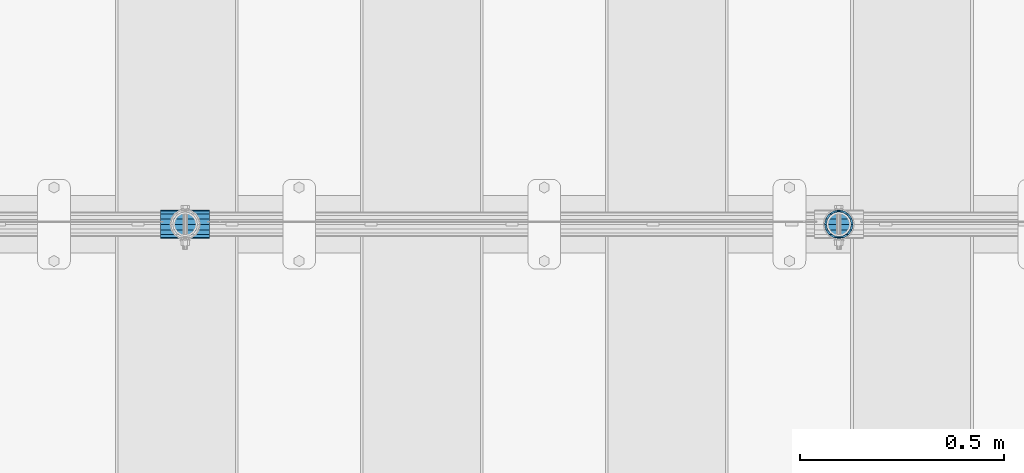
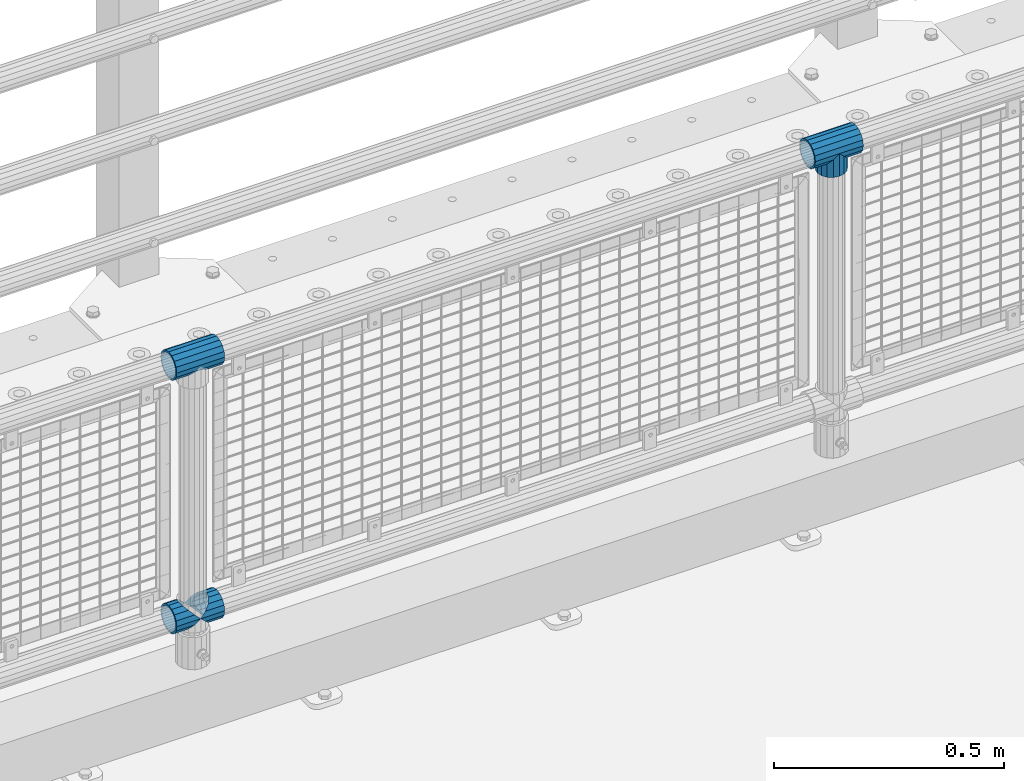
# One storey, part 152 of 247: 5 beams.
"""IFC2X3 building model written with IfcOpenShell, lengths in millimetres."""

from ifc_helpers import new_model, si_unit, frame, origin_with_axes, place, context, subcontext, project, spatial, faceted_brep, material, type_object, element, save


model = new_model("IFC2X3")

# Units and contexts
model_context = context("Model", 3, precision=1e-05, world=origin_with_axes())
body_context = subcontext(model_context, "Body", "Model", "MODEL_VIEW")
ifc_project = project(units=[si_unit("LENGTHUNIT", "METRE", prefix="MILLI"), si_unit("AREAUNIT", "SQUARE_METRE"), si_unit("VOLUMEUNIT", "CUBIC_METRE"), si_unit("MASSUNIT", "GRAM", prefix="KILO"), si_unit("TIMEUNIT", "SECOND"), si_unit("PLANEANGLEUNIT", "RADIAN"), si_unit("SOLIDANGLEUNIT", "STERADIAN"), si_unit("THERMODYNAMICTEMPERATUREUNIT", "DEGREE_CELSIUS"), si_unit("LUMINOUSINTENSITYUNIT", "LUMEN")], contexts=[model_context])

# Site, building, storey
site_placement = place(None, origin_with_axes())
site = spatial("IfcSite", under=ifc_project, at=site_placement, CompositionType="ELEMENT")
building_placement = place(site_placement, origin_with_axes())
building = spatial("IfcBuilding", under=site, at=building_placement, Name="Standard", CompositionType="ELEMENT")
storey_placement = place(building_placement, origin_with_axes())
storey = spatial("IfcBuildingStorey", under=building, at=storey_placement, Name="Undefined", CompositionType="ELEMENT", Elevation=0.0)

# Beams
ifc_material = material(Name="Misc_Undefined")
beam_type = type_object("IfcBeamType", PredefinedType="NOTDEFINED")
beam_1_placement = place(storey_placement, frame((8621.0, 7664.5, 969.849999999999), z_axis=(0.0, 1.0, 0.0), x_axis=(0.0, 0.0, -1.0)))
element("IfcBeam", 1, at=beam_1_placement, inside=storey, type_object=beam_type, material=ifc_material, context=body_context, shape_type="Brep", body=[
    faceted_brep([(0.0, 0.0, 35.1499999999996), (13.4513226476338, 13.4513226476329, 32.4743655677721), (13.4513226476338, -13.4513226476329, 32.4743655677721), (24.8548033587067, -16.3810424080045, -24.8548033587067), (24.8548033587067, -24.8548033587072, -24.8548033587067), (32.4743655677721, -32.4743655677717, -13.4513226476329), (32.4743655677721, -26.8123795176766, -13.4513226476329), (27.1226768591059, -21.4606908090117, -21.4606908090118), (0.0, 0.0, -35.1499999999996), (13.4513226476338, -13.4513226476329, -32.4743655677721), (13.4513226476338, 13.4513226476329, -32.4743655677721), (20.0882031229885, -11.6144421722805, -28.0397438117179), (16.6306603983739, 0.0, -30.3500000000004), (20.0882031229885, 11.6144421722805, -28.0397438117179), (24.8548033587067, 16.3810424080029, -24.8548033587067), (24.8548033587067, 24.8548033587072, -24.8548033587067), (27.1226768591059, 21.4606908090117, -21.4606908090118), (32.4743655677721, 26.8123795176755, -13.4513226476329), (32.4743655677721, 32.4743655677717, -13.4513226476329), (32.8397438117172, 28.0397438117175, -11.6144421722802), (35.1499999999996, 30.35, 0.0), (35.1499999999996, 35.15, 0.0), (32.8397438117172, 28.0397438117175, 11.6144421722802), (32.4743655677721, 26.8123795176755, 13.4513226476329), (32.4743655677721, 32.4743655677717, 13.4513226476329), (27.1226768591096, 21.4606908090117, 21.4606908090118), (24.8548033587067, 16.3810424080046, 24.8548033587067), (24.8548033587067, 24.8548033587072, 24.8548033587067), (20.0882031229812, 11.6144421722805, 28.0397438117179), (16.6306603983649, 0.0, 30.3500000000004), (20.0882031229812, -11.6144421722805, 28.0397438117179), (24.8548033587067, -16.3810424080045, 24.8548033587067), (24.8548033587067, -24.8548033587072, 24.8548033587067), (27.1226768591096, -21.4606908090117, 21.4606908090118), (32.4743655677721, -26.8123795176755, 13.4513226476329), (32.4743655677721, -32.4743655677717, 13.4513226476329), (32.8397438117172, -28.0397438117175, 11.6144421722802), (35.1499999999996, -30.35, 0.0), (35.1499999999996, -35.15, 0.0), (32.8397438117172, -28.0397438117175, -11.6144421722802), (60.1499999999996, -24.8548033587072, -24.8548033587067), (60.1499999999996, -32.4743655677717, -13.4513226476329), (60.1499999999996, -13.4513226476329, -32.4743655677721), (60.1499999999996, 0.0, -35.1499999999996), (60.1499999999996, 13.4513226476329, -32.4743655677721), (60.1499999999996, 24.8548033587072, -24.8548033587067), (60.1499999999996, 32.4743655677717, -13.4513226476329), (60.1499999999996, 35.15, 0.0), (60.1499999999996, 32.4743655677717, 13.4513226476329), (60.1499999999996, 24.8548033587072, 24.8548033587067), (60.1499999999996, 13.4513226476329, 32.4743655677721), (60.1499999999996, 0.0, 35.1499999999996), (60.1499999999996, -13.4513226476329, 32.4743655677721), (60.1499999999996, -24.8548033587072, 24.8548033587067), (60.1499999999996, -32.4743655677717, 13.4513226476329), (60.1499999999996, -35.15, 0.0), (60.1499999999996, -21.4606908090117, 21.4606908090118), (60.1499999999996, -11.6144421722805, 28.0397438117179), (60.1499999999996, 0.0, 30.3500000000004), (60.1499999999996, 11.6144421722805, 28.0397438117179), (60.1499999999996, 21.4606908090117, 21.4606908090118), (60.1499999999996, 28.0397438117175, 11.6144421722802), (60.1499999999996, 30.35, 0.0), (60.1499999999996, 28.0397438117175, -11.6144421722802), (60.1499999999996, 21.4606908090117, -21.4606908090118), (60.1499999999996, 11.6144421722805, -28.0397438117179), (60.1499999999996, 0.0, -30.3500000000004), (60.1499999999996, -11.6144421722805, -28.0397438117179), (60.1499999999996, -21.4606908090117, -21.4606908090118), (60.1499999999996, -28.0397438117175, -11.6144421722802), (60.1499999999996, -30.35, 0.0), (60.1499999999996, -28.0397438117175, 11.6144421722802)], [[[0, 1, 2]], [[3, 4, 5, 6, 7]], [[8, 9, 10]], [[10, 9, 4, 3, 11, 12, 13, 14, 15]], [[15, 14, 16, 17, 18]], [[18, 17, 19, 20, 21]], [[21, 20, 22, 23, 24]], [[24, 23, 25, 26, 27]], [[27, 26, 28, 29, 30, 31, 32, 2, 1]], [[33, 34, 35, 32, 31]], [[36, 37, 38, 35, 34]], [[6, 5, 38, 37, 39]], [[40, 41, 5, 4]], [[42, 40, 4, 9]], [[43, 42, 9, 8]], [[44, 43, 8, 10]], [[45, 44, 10, 15]], [[46, 45, 15, 18]], [[47, 46, 18, 21]], [[48, 47, 21, 24]], [[49, 48, 24, 27]], [[50, 49, 27, 1]], [[51, 50, 1, 0]], [[52, 51, 0, 2]], [[53, 52, 2, 32]], [[54, 53, 32, 35]], [[55, 54, 35, 38]], [[41, 55, 38, 5]], [[40, 42, 43, 44, 45, 46, 47, 48, 49, 50, 51, 52, 53, 54, 55, 41], [56, 57, 58, 59, 60, 61, 62, 63, 64, 65, 66, 67, 68, 69, 70, 71]], [[71, 70, 37, 36]], [[56, 71, 36, 34, 33]], [[57, 56, 33, 31, 30]], [[58, 57, 30, 29]], [[59, 58, 29, 28]], [[25, 60, 59, 28, 26]], [[22, 61, 60, 25, 23]], [[62, 61, 22, 20]], [[63, 62, 20, 19]], [[64, 63, 19, 17, 16]], [[65, 64, 16, 14, 13]], [[66, 65, 13, 12]], [[67, 66, 12, 11]], [[7, 68, 67, 11, 3]], [[39, 69, 68, 7, 6]], [[70, 69, 39, 37]]]),
])
beam_2_placement = place(storey_placement, frame((8560.85, 7664.5, 969.849999999999), z_axis=(0.0, 0.0, 1.0), x_axis=(1.0, 0.0, 0.0)))
element("IfcBeam", 2, at=beam_2_placement, inside=storey, type_object=beam_type, material=ifc_material, context=body_context, shape_type="Brep", body=[
    faceted_brep([(88.1897438117176, -11.6144421722802, -28.0397438117176), (88.1897438117176, -11.6144421722802, -32.8397438117175), (86.9623795176758, -13.4513226476329, -32.4743655677718), (81.6106908090114, -21.4606908090118, -27.1226768591068), (81.6106908090114, -21.4606908090118, -21.4606908090117), (76.5310424080035, -24.8548033587067, -24.8548033587072), (71.7644421722798, -28.0397438117179, -20.0882031229845), (71.7644421722798, -28.0397438117179, -11.6144421722805), (60.1499999999996, -30.3500000000004, -16.6306603983671), (60.1499999999996, -30.35, 0.0), (48.5355578277195, -28.0397438117179, -20.0882031229845), (48.5355578277195, -28.0397438117179, -11.6144421722805), (43.7689575919958, -24.8548033587067, -24.8548033587072), (38.6893091909878, -21.4606908090118, -27.1226768591068), (38.6893091909878, -21.4606908090118, -21.4606908090117), (33.3376204823217, -13.4513226476329, -32.4743655677718), (32.1102561882817, -11.6144421722802, -32.8397438117175), (32.1102561882817, -11.6144421722802, -28.0397438117176), (29.7999999999993, 0.0, -35.15), (29.7999999999993, 0.0, -30.35), (32.1102561882817, 11.6144421722802, -32.8397438117174), (32.1102561882817, 11.6144421722802, -28.0397438117176), (33.3376204823235, 13.4513226476329, -32.4743655677718), (38.6893091909878, 21.4606908090118, -27.122676859108), (38.6893091909878, 21.4606908090118, -21.4606908090117), (43.7689575919976, 24.8548033587067, -24.8548033587072), (48.5355578277195, 28.0397438117179, -20.0882031229829), (48.5355578277195, 28.0397438117179, -11.6144421722805), (60.1499999999996, 30.3500000000004, -16.6306603983655), (60.1499999999996, 30.35, 0.0), (71.7644421722798, 28.0397438117179, -20.0882031229829), (71.7644421722798, 28.0397438117179, -11.6144421722805), (76.5310424080035, 24.8548033587067, -24.8548033587072), (81.6106908090114, 21.4606908090118, -27.122676859108), (81.6106908090114, 21.4606908090118, -21.4606908090117), (86.9623795176758, 13.4513226476329, -32.4743655677718), (88.1897438117176, 11.6144421722802, -32.8397438117174), (88.1897438117176, 11.6144421722802, -28.0397438117176), (90.5, 0.0, -35.15), (90.5, 0.0, -30.35), (0.0, -21.4606908090118, -21.4606908090118), (0.0, -28.0397438117179, -11.6144421722802), (0.0, -11.6144421722802, -28.0397438117179), (0.0, 0.0, -30.3500000000004), (0.0, 11.6144421722802, -28.0397438117179), (0.0, 21.4606908090118, -21.4606908090118), (0.0, 28.0397438117179, -11.6144421722802), (0.0, 30.3500000000004, 0.0), (0.0, 32.4743655677721, -13.4513226476338), (0.0, 35.1499999999996, 0.0), (120.299999999999, 35.1499999999996, 0.0), (120.299999999999, 32.4743655677721, -13.4513226476329), (0.0, 32.4743655677721, 13.4513226476338), (120.299999999999, 32.4743655677721, 13.4513226476329), (0.0, 24.8548033587067, 24.8548033587067), (120.299999999999, 24.8548033587067, 24.8548033587072), (0.0, 13.4513226476329, 32.4743655677721), (120.299999999999, 13.4513226476329, 32.4743655677718), (0.0, 0.0, 35.1499999999996), (120.299999999999, 0.0, 35.15), (0.0, -13.4513226476329, 32.4743655677721), (120.299999999999, -13.4513226476329, 32.4743655677718), (0.0, -24.8548033587067, 24.8548033587067), (120.299999999999, -24.8548033587067, 24.8548033587072), (0.0, -32.4743655677721, 13.4513226476338), (120.299999999999, -32.4743655677721, 13.4513226476329), (0.0, -35.1499999999996, 0.0), (120.299999999999, -35.1499999999996, 0.0), (0.0, -32.4743655677721, -13.4513226476338), (120.299999999999, -32.4743655677721, -13.4513226476329), (0.0, 24.8548033587067, -24.8548033587067), (0.0, 13.4513226476329, -32.4743655677721), (0.0, 0.0, -35.1499999999996), (0.0, -13.4513226476329, -32.4743655677721), (0.0, -24.8548033587067, -24.8548033587067), (0.0, 28.0397438117179, 11.6144421722802), (0.0, 21.4606908090118, 21.4606908090118), (0.0, 11.6144421722802, 28.0397438117179), (0.0, 0.0, 30.3500000000004), (0.0, -11.6144421722802, 28.0397438117179), (0.0, -21.4606908090118, 21.4606908090118), (0.0, -28.0397438117179, 11.6144421722802), (0.0, -30.3500000000004, 0.0), (120.299999999999, -30.3500000000004, 0.0), (120.299999999999, -28.0397438117179, -11.6144421722805), (120.299999999999, -21.4606908090118, -21.4606908090117), (120.299999999999, -11.6144421722802, -28.0397438117176), (120.299999999999, 0.0, -30.35), (120.299999999999, 21.4606908090118, -21.4606908090117), (120.299999999999, 28.0397438117179, -11.6144421722805), (120.299999999999, 11.6144421722802, -28.0397438117176), (120.299999999999, 30.3500000000004, 0.0), (120.299999999999, 28.0397438117179, 11.6144421722805), (120.299999999999, 21.4606908090118, 21.4606908090117), (120.299999999999, 11.6144421722802, 28.0397438117176), (120.299999999999, 0.0, 30.35), (120.299999999999, -11.6144421722802, 28.0397438117176), (120.299999999999, -21.4606908090118, 21.4606908090117), (120.299999999999, -28.0397438117179, 11.6144421722805), (120.299999999999, -24.8548033587067, -24.8548033587072), (120.299999999999, -13.4513226476329, -32.4743655677718), (120.299999999999, 0.0, -35.15), (120.299999999999, 13.4513226476329, -32.4743655677718), (120.299999999999, 24.8548033587067, -24.8548033587072)], [[[0, 1, 2, 3, 4]], [[4, 3, 5, 6, 7]], [[7, 6, 8, 9]], [[9, 8, 10, 11]], [[11, 10, 12, 13, 14]], [[14, 13, 15, 16, 17]], [[17, 16, 18, 19]], [[19, 18, 20, 21]], [[21, 20, 22, 23, 24]], [[24, 23, 25, 26, 27]], [[27, 26, 28, 29]], [[29, 28, 30, 31]], [[31, 30, 32, 33, 34]], [[34, 33, 35, 36, 37]], [[37, 36, 38, 39]], [[39, 38, 1, 0]], [[40, 41, 11, 14]], [[42, 40, 14, 17]], [[43, 42, 17, 19]], [[44, 43, 19, 21]], [[45, 44, 21, 24]], [[46, 45, 24, 27]], [[47, 46, 27, 29]], [[48, 49, 50, 51]], [[49, 52, 53, 50]], [[52, 54, 55, 53]], [[54, 56, 57, 55]], [[56, 58, 59, 57]], [[58, 60, 61, 59]], [[60, 62, 63, 61]], [[62, 64, 65, 63]], [[64, 66, 67, 65]], [[66, 68, 69, 67]], [[64, 62, 60, 58, 56, 54, 52, 49, 48, 70, 71, 72, 73, 74, 68, 66], [41, 40, 42, 43, 44, 45, 46, 47, 75, 76, 77, 78, 79, 80, 81, 82]], [[41, 82, 9, 11]], [[83, 84, 7, 9]], [[84, 85, 4, 7]], [[85, 86, 0, 4]], [[86, 87, 39, 0]], [[88, 89, 31, 34]], [[90, 88, 34, 37]], [[87, 90, 37, 39]], [[89, 91, 29, 31]], [[75, 47, 29, 91, 92]], [[76, 75, 92, 93]], [[77, 76, 93, 94]], [[78, 77, 94, 95]], [[79, 78, 95, 96]], [[80, 79, 96, 97]], [[81, 80, 97, 98]], [[9, 82, 81, 98, 83]], [[99, 100, 101, 102, 103, 51, 50, 53, 55, 57, 59, 61, 63, 65, 67, 69], [97, 96, 95, 94, 93, 92, 91, 89, 88, 90, 87, 86, 85, 84, 83, 98]], [[35, 102, 101, 38, 36]], [[32, 103, 102, 35, 33]], [[28, 26, 25, 70, 48, 51, 103, 32, 30]], [[22, 71, 70, 25, 23]], [[18, 72, 71, 22, 20]], [[73, 72, 18, 16, 15]], [[74, 73, 15, 13, 12]], [[99, 69, 68, 74, 12, 10, 8, 6, 5]], [[100, 99, 5, 3, 2]], [[101, 100, 2, 1, 38]]]),
])
beam_3_placement = place(storey_placement, frame((6960.85, 7664.5, 969.849999999999), z_axis=(0.0, 0.0, 1.0), x_axis=(1.0, 0.0, 0.0)))
element("IfcBeam", 3, at=beam_3_placement, inside=storey, type_object=beam_type, material=ifc_material, context=body_context, shape_type="Brep", body=[
    faceted_brep([(88.1897438117176, -11.6144421722802, -28.0397438117176), (88.1897438117176, -11.6144421722802, -32.8397438117175), (86.9623795176758, -13.4513226476329, -32.4743655677718), (81.6106908090114, -21.4606908090118, -27.1226768591068), (81.6106908090114, -21.4606908090118, -21.4606908090117), (76.5310424080035, -24.8548033587067, -24.8548033587072), (71.7644421722798, -28.0397438117179, -20.0882031229845), (71.7644421722798, -28.0397438117179, -11.6144421722805), (60.1499999999996, -30.3500000000004, -16.6306603983671), (60.1499999999996, -30.35, 0.0), (48.5355578277195, -28.0397438117179, -20.0882031229845), (48.5355578277195, -28.0397438117179, -11.6144421722805), (43.7689575919958, -24.8548033587067, -24.8548033587072), (38.6893091909878, -21.4606908090118, -27.1226768591068), (38.6893091909878, -21.4606908090118, -21.4606908090117), (33.3376204823217, -13.4513226476329, -32.4743655677718), (32.1102561882817, -11.6144421722802, -32.8397438117175), (32.1102561882817, -11.6144421722802, -28.0397438117176), (29.7999999999993, 0.0, -35.15), (29.7999999999993, 0.0, -30.35), (32.1102561882817, 11.6144421722802, -32.8397438117174), (32.1102561882817, 11.6144421722802, -28.0397438117176), (33.3376204823235, 13.4513226476329, -32.4743655677718), (38.6893091909878, 21.4606908090118, -27.122676859108), (38.6893091909878, 21.4606908090118, -21.4606908090117), (43.7689575919976, 24.8548033587067, -24.8548033587072), (48.5355578277195, 28.0397438117179, -20.0882031229829), (48.5355578277195, 28.0397438117179, -11.6144421722805), (60.1499999999996, 30.3500000000004, -16.6306603983655), (60.1499999999996, 30.35, 0.0), (71.7644421722798, 28.0397438117179, -20.0882031229829), (71.7644421722798, 28.0397438117179, -11.6144421722805), (76.5310424080035, 24.8548033587067, -24.8548033587072), (81.6106908090114, 21.4606908090118, -27.122676859108), (81.6106908090114, 21.4606908090118, -21.4606908090117), (86.9623795176758, 13.4513226476329, -32.4743655677718), (88.1897438117176, 11.6144421722802, -32.8397438117174), (88.1897438117176, 11.6144421722802, -28.0397438117176), (90.5, 0.0, -35.15), (90.5, 0.0, -30.35), (0.0, -21.4606908090118, -21.4606908090118), (0.0, -28.0397438117179, -11.6144421722802), (0.0, -11.6144421722802, -28.0397438117179), (0.0, 0.0, -30.3500000000004), (0.0, 11.6144421722802, -28.0397438117179), (0.0, 21.4606908090118, -21.4606908090118), (0.0, 28.0397438117179, -11.6144421722802), (0.0, 30.3500000000004, 0.0), (0.0, 32.4743655677721, -13.4513226476338), (0.0, 35.1499999999996, 0.0), (120.299999999999, 35.1499999999996, 0.0), (120.299999999999, 32.4743655677721, -13.4513226476329), (0.0, 32.4743655677721, 13.4513226476338), (120.299999999999, 32.4743655677721, 13.4513226476329), (0.0, 24.8548033587067, 24.8548033587067), (120.299999999999, 24.8548033587067, 24.8548033587072), (0.0, 13.4513226476329, 32.4743655677721), (120.299999999999, 13.4513226476329, 32.4743655677718), (0.0, 0.0, 35.1499999999996), (120.299999999999, 0.0, 35.15), (0.0, -13.4513226476329, 32.4743655677721), (120.299999999999, -13.4513226476329, 32.4743655677718), (0.0, -24.8548033587067, 24.8548033587067), (120.299999999999, -24.8548033587067, 24.8548033587072), (0.0, -32.4743655677721, 13.4513226476338), (120.299999999999, -32.4743655677721, 13.4513226476329), (0.0, -35.1499999999996, 0.0), (120.299999999999, -35.1499999999996, 0.0), (0.0, -32.4743655677721, -13.4513226476338), (120.299999999999, -32.4743655677721, -13.4513226476329), (0.0, 24.8548033587067, -24.8548033587067), (0.0, 13.4513226476329, -32.4743655677721), (0.0, 0.0, -35.1499999999996), (0.0, -13.4513226476329, -32.4743655677721), (0.0, -24.8548033587067, -24.8548033587067), (0.0, 28.0397438117179, 11.6144421722802), (0.0, 21.4606908090118, 21.4606908090118), (0.0, 11.6144421722802, 28.0397438117179), (0.0, 0.0, 30.3500000000004), (0.0, -11.6144421722802, 28.0397438117179), (0.0, -21.4606908090118, 21.4606908090118), (0.0, -28.0397438117179, 11.6144421722802), (0.0, -30.3500000000004, 0.0), (120.299999999999, -30.3500000000004, 0.0), (120.299999999999, -28.0397438117179, -11.6144421722805), (120.299999999999, -21.4606908090118, -21.4606908090117), (120.299999999999, -11.6144421722802, -28.0397438117176), (120.299999999999, 0.0, -30.35), (120.299999999999, 21.4606908090118, -21.4606908090117), (120.299999999999, 28.0397438117179, -11.6144421722805), (120.299999999999, 11.6144421722802, -28.0397438117176), (120.299999999999, 30.3500000000004, 0.0), (120.299999999999, 28.0397438117179, 11.6144421722805), (120.299999999999, 21.4606908090118, 21.4606908090117), (120.299999999999, 11.6144421722802, 28.0397438117176), (120.299999999999, 0.0, 30.35), (120.299999999999, -11.6144421722802, 28.0397438117176), (120.299999999999, -21.4606908090118, 21.4606908090117), (120.299999999999, -28.0397438117179, 11.6144421722805), (120.299999999999, -24.8548033587067, -24.8548033587072), (120.299999999999, -13.4513226476329, -32.4743655677718), (120.299999999999, 0.0, -35.15), (120.299999999999, 13.4513226476329, -32.4743655677718), (120.299999999999, 24.8548033587067, -24.8548033587072)], [[[0, 1, 2, 3, 4]], [[4, 3, 5, 6, 7]], [[7, 6, 8, 9]], [[9, 8, 10, 11]], [[11, 10, 12, 13, 14]], [[14, 13, 15, 16, 17]], [[17, 16, 18, 19]], [[19, 18, 20, 21]], [[21, 20, 22, 23, 24]], [[24, 23, 25, 26, 27]], [[27, 26, 28, 29]], [[29, 28, 30, 31]], [[31, 30, 32, 33, 34]], [[34, 33, 35, 36, 37]], [[37, 36, 38, 39]], [[39, 38, 1, 0]], [[40, 41, 11, 14]], [[42, 40, 14, 17]], [[43, 42, 17, 19]], [[44, 43, 19, 21]], [[45, 44, 21, 24]], [[46, 45, 24, 27]], [[47, 46, 27, 29]], [[48, 49, 50, 51]], [[49, 52, 53, 50]], [[52, 54, 55, 53]], [[54, 56, 57, 55]], [[56, 58, 59, 57]], [[58, 60, 61, 59]], [[60, 62, 63, 61]], [[62, 64, 65, 63]], [[64, 66, 67, 65]], [[66, 68, 69, 67]], [[64, 62, 60, 58, 56, 54, 52, 49, 48, 70, 71, 72, 73, 74, 68, 66], [41, 40, 42, 43, 44, 45, 46, 47, 75, 76, 77, 78, 79, 80, 81, 82]], [[41, 82, 9, 11]], [[83, 84, 7, 9]], [[84, 85, 4, 7]], [[85, 86, 0, 4]], [[86, 87, 39, 0]], [[88, 89, 31, 34]], [[90, 88, 34, 37]], [[87, 90, 37, 39]], [[89, 91, 29, 31]], [[75, 47, 29, 91, 92]], [[76, 75, 92, 93]], [[77, 76, 93, 94]], [[78, 77, 94, 95]], [[79, 78, 95, 96]], [[80, 79, 96, 97]], [[81, 80, 97, 98]], [[9, 82, 81, 98, 83]], [[99, 100, 101, 102, 103, 51, 50, 53, 55, 57, 59, 61, 63, 65, 67, 69], [97, 96, 95, 94, 93, 92, 91, 89, 88, 90, 87, 86, 85, 84, 83, 98]], [[35, 102, 101, 38, 36]], [[32, 103, 102, 35, 33]], [[28, 26, 25, 70, 48, 51, 103, 32, 30]], [[22, 71, 70, 25, 23]], [[18, 72, 71, 22, 20]], [[73, 72, 18, 16, 15]], [[74, 73, 15, 13, 12]], [[99, 69, 68, 74, 12, 10, 8, 6, 5]], [[100, 99, 5, 3, 2]], [[101, 100, 2, 1, 38]]]),
])
beam_4_placement = place(storey_placement, frame((6960.85, 7664.5, 298.17), z_axis=(0.0, 1.0, 0.0), x_axis=(1.0, 0.0, 0.0)))
element("IfcBeam", 4, at=beam_4_placement, inside=storey, type_object=beam_type, material=ifc_material, context=body_context, shape_type="Brep", body=[
    faceted_brep([(60.1499999999996, 0.0, -35.1499999999996), (46.6986773523668, 13.4513226476329, -32.4743655677721), (46.6986773523668, -13.4513226476329, -32.4743655677721), (33.0273231408919, 21.4606908090117, 21.4606908090118), (27.675634432228, 26.8123795176755, 13.4513226476329), (27.675634432228, 32.4743655677717, 13.4513226476329), (35.2951966412925, 24.8548033587072, 24.8548033587067), (35.2951966412925, 16.3810424080048, 24.8548033587067), (27.3102561882824, 28.0397438117175, 11.6144421722802), (24.9999999999995, 30.35, 0.0), (24.9999999999995, 35.15, 0.0), (27.675634432228, 26.8123795176764, -13.4513226476329), (27.675634432228, 32.4743655677717, -13.4513226476329), (27.310256188282, 28.0397438117175, -11.6144421722802), (35.2951966412925, 16.3810424080032, -24.8548033587067), (35.2951966412925, 24.8548033587072, -24.8548033587067), (33.0273231408928, 21.4606908090117, -21.4606908090118), (40.0617968770157, 11.6144421722805, -28.0397438117179), (43.5193396016348, 0.0, -30.3500000000004), (40.0617968770157, -11.6144421722805, -28.0397438117179), (35.2951966412925, -16.3810424080032, -24.8548033587067), (35.2951966412925, -24.8548033587072, -24.8548033587067), (33.0273231408928, -21.4606908090117, -21.4606908090118), (27.675634432228, -26.8123795176766, -13.4513226476329), (27.675634432228, -32.4743655677717, -13.4513226476329), (27.310256188282, -28.0397438117175, -11.6144421722802), (24.9999999999995, -30.35, 0.0), (24.9999999999995, -35.15, 0.0), (27.3102561882824, -28.0397438117175, 11.6144421722802), (27.675634432228, -26.8123795176764, 13.4513226476329), (27.675634432228, -32.4743655677717, 13.4513226476329), (33.0273231408919, -21.4606908090117, 21.4606908090118), (35.2951966412925, -16.3810424080032, 24.8548033587067), (35.2951966412925, -24.8548033587072, 24.8548033587067), (60.1499999999996, 0.0, 35.1499999999996), (46.6986773523668, -13.4513226476329, 32.4743655677721), (46.6986773523668, 13.4513226476329, 32.4743655677721), (40.0617968770157, -11.6144421722805, 28.0397438117179), (43.519339601633, 0.0, 30.3500000000004), (40.0617968770157, 11.6144421722805, 28.0397438117179), (0.0, -32.4743655677721, -13.4513226476338), (0.0, -24.8548033587067, -24.8548033587067), (0.0, -13.4513226476329, -32.4743655677721), (0.0, 0.0, -35.1499999999996), (0.0, 13.4513226476329, -32.4743655677721), (0.0, 24.8548033587067, -24.8548033587067), (0.0, 32.4743655677721, -13.4513226476338), (0.0, 35.1499999999996, 0.0), (0.0, 32.4743655677721, 13.4513226476338), (0.0, 24.8548033587067, 24.8548033587067), (0.0, 13.4513226476329, 32.4743655677721), (0.0, 0.0, 35.1499999999996), (0.0, -32.4743655677721, 13.4513226476338), (0.0, -35.1499999999996, 0.0), (0.0, -24.8548033587067, 24.8548033587067), (0.0, -13.4513226476329, 32.4743655677721), (0.0, -28.0397438117179, -11.6144421722802), (0.0, -21.4606908090118, -21.4606908090118), (0.0, -11.6144421722802, -28.0397438117179), (0.0, 0.0, -30.3500000000004), (0.0, 11.6144421722802, -28.0397438117179), (0.0, 21.4606908090118, -21.4606908090118), (0.0, 28.0397438117179, -11.6144421722802), (0.0, 30.3500000000004, 0.0), (0.0, 28.0397438117179, 11.6144421722802), (0.0, 21.4606908090118, 21.4606908090118), (0.0, 11.6144421722802, 28.0397438117179), (0.0, 0.0, 30.3500000000004), (0.0, -11.6144421722802, 28.0397438117179), (0.0, -21.4606908090118, 21.4606908090118), (0.0, -28.0397438117179, 11.6144421722802), (0.0, -30.3500000000004, 0.0)], [[[0, 1, 2]], [[3, 4, 5, 6, 7]], [[8, 9, 10, 5, 4]], [[11, 12, 10, 9, 13]], [[14, 15, 12, 11, 16]], [[2, 1, 15, 14, 17, 18, 19, 20, 21]], [[21, 20, 22, 23, 24]], [[24, 23, 25, 26, 27]], [[27, 26, 28, 29, 30]], [[30, 29, 31, 32, 33]], [[34, 35, 36]], [[33, 32, 37, 38, 39, 7, 6, 36, 35]], [[40, 41, 21, 24]], [[41, 42, 2, 21]], [[42, 43, 0, 2]], [[43, 44, 1, 0]], [[44, 45, 15, 1]], [[45, 46, 12, 15]], [[46, 47, 10, 12]], [[47, 48, 5, 10]], [[48, 49, 6, 5]], [[49, 50, 36, 6]], [[50, 51, 34, 36]], [[52, 53, 27, 30]], [[54, 52, 30, 33]], [[55, 54, 33, 35]], [[51, 55, 35, 34]], [[53, 40, 24, 27]], [[52, 54, 55, 51, 50, 49, 48, 47, 46, 45, 44, 43, 42, 41, 40, 53], [56, 57, 58, 59, 60, 61, 62, 63, 64, 65, 66, 67, 68, 69, 70, 71]], [[68, 67, 38, 37]], [[31, 69, 68, 37, 32]], [[28, 70, 69, 31, 29]], [[71, 70, 28, 26]], [[56, 71, 26, 25]], [[57, 56, 25, 23, 22]], [[58, 57, 22, 20, 19]], [[59, 58, 19, 18]], [[60, 59, 18, 17]], [[16, 61, 60, 17, 14]], [[13, 62, 61, 16, 11]], [[63, 62, 13, 9]], [[64, 63, 9, 8]], [[65, 64, 8, 4, 3]], [[66, 65, 3, 7, 39]], [[67, 66, 39, 38]]]),
])
beam_5_placement = place(storey_placement, frame((7021.0, 7664.5, 298.17), z_axis=(0.0, 1.0, 0.0), x_axis=(1.0, 0.0, 0.0)))
element("IfcBeam", 5, at=beam_5_placement, inside=storey, type_object=beam_type, material=ifc_material, context=body_context, shape_type="Brep", body=[
    faceted_brep([(0.0, 0.0, 35.1499999999996), (13.4513226476338, 13.4513226476329, 32.4743655677721), (13.4513226476338, -13.4513226476329, 32.4743655677721), (24.8548033587067, -16.3810424080045, -24.8548033587067), (24.8548033587067, -24.8548033587072, -24.8548033587067), (32.4743655677721, -32.4743655677717, -13.4513226476329), (32.4743655677721, -26.8123795176766, -13.4513226476329), (27.1226768591059, -21.4606908090117, -21.4606908090118), (0.0, 0.0, -35.1499999999996), (13.4513226476338, -13.4513226476329, -32.4743655677721), (13.4513226476338, 13.4513226476329, -32.4743655677721), (20.0882031229885, -11.6144421722805, -28.0397438117179), (16.6306603983739, 0.0, -30.3500000000004), (20.0882031229885, 11.6144421722805, -28.0397438117179), (24.8548033587067, 16.3810424080029, -24.8548033587067), (24.8548033587067, 24.8548033587072, -24.8548033587067), (27.1226768591059, 21.4606908090117, -21.4606908090118), (32.4743655677721, 26.8123795176755, -13.4513226476329), (32.4743655677721, 32.4743655677717, -13.4513226476329), (32.8397438117172, 28.0397438117175, -11.6144421722802), (35.1499999999996, 30.35, 0.0), (35.1499999999996, 35.15, 0.0), (32.8397438117172, 28.0397438117175, 11.6144421722802), (32.4743655677721, 26.8123795176755, 13.4513226476329), (32.4743655677721, 32.4743655677717, 13.4513226476329), (27.1226768591096, 21.4606908090117, 21.4606908090118), (24.8548033587067, 16.3810424080046, 24.8548033587067), (24.8548033587067, 24.8548033587072, 24.8548033587067), (20.0882031229812, 11.6144421722805, 28.0397438117179), (16.6306603983649, 0.0, 30.3500000000004), (20.0882031229812, -11.6144421722805, 28.0397438117179), (24.8548033587067, -16.3810424080045, 24.8548033587067), (24.8548033587067, -24.8548033587072, 24.8548033587067), (27.1226768591096, -21.4606908090117, 21.4606908090118), (32.4743655677721, -26.8123795176755, 13.4513226476329), (32.4743655677721, -32.4743655677717, 13.4513226476329), (32.8397438117172, -28.0397438117175, 11.6144421722802), (35.1499999999996, -30.35, 0.0), (35.1499999999996, -35.15, 0.0), (32.8397438117172, -28.0397438117175, -11.6144421722802), (60.1499999999996, -24.8548033587072, -24.8548033587067), (60.1499999999996, -32.4743655677717, -13.4513226476329), (60.1499999999996, -13.4513226476329, -32.4743655677721), (60.1499999999996, 0.0, -35.1499999999996), (60.1499999999996, 13.4513226476329, -32.4743655677721), (60.1499999999996, 24.8548033587072, -24.8548033587067), (60.1499999999996, 32.4743655677717, -13.4513226476329), (60.1499999999996, 35.15, 0.0), (60.1499999999996, 32.4743655677717, 13.4513226476329), (60.1499999999996, 24.8548033587072, 24.8548033587067), (60.1499999999996, 13.4513226476329, 32.4743655677721), (60.1499999999996, 0.0, 35.1499999999996), (60.1499999999996, -13.4513226476329, 32.4743655677721), (60.1499999999996, -24.8548033587072, 24.8548033587067), (60.1499999999996, -32.4743655677717, 13.4513226476329), (60.1499999999996, -35.15, 0.0), (60.1499999999996, -21.4606908090117, 21.4606908090118), (60.1499999999996, -11.6144421722805, 28.0397438117179), (60.1499999999996, 0.0, 30.3500000000004), (60.1499999999996, 11.6144421722805, 28.0397438117179), (60.1499999999996, 21.4606908090117, 21.4606908090118), (60.1499999999996, 28.0397438117175, 11.6144421722802), (60.1499999999996, 30.35, 0.0), (60.1499999999996, 28.0397438117175, -11.6144421722802), (60.1499999999996, 21.4606908090117, -21.4606908090118), (60.1499999999996, 11.6144421722805, -28.0397438117179), (60.1499999999996, 0.0, -30.3500000000004), (60.1499999999996, -11.6144421722805, -28.0397438117179), (60.1499999999996, -21.4606908090117, -21.4606908090118), (60.1499999999996, -28.0397438117175, -11.6144421722802), (60.1499999999996, -30.35, 0.0), (60.1499999999996, -28.0397438117175, 11.6144421722802)], [[[0, 1, 2]], [[3, 4, 5, 6, 7]], [[8, 9, 10]], [[10, 9, 4, 3, 11, 12, 13, 14, 15]], [[15, 14, 16, 17, 18]], [[18, 17, 19, 20, 21]], [[21, 20, 22, 23, 24]], [[24, 23, 25, 26, 27]], [[27, 26, 28, 29, 30, 31, 32, 2, 1]], [[33, 34, 35, 32, 31]], [[36, 37, 38, 35, 34]], [[6, 5, 38, 37, 39]], [[40, 41, 5, 4]], [[42, 40, 4, 9]], [[43, 42, 9, 8]], [[44, 43, 8, 10]], [[45, 44, 10, 15]], [[46, 45, 15, 18]], [[47, 46, 18, 21]], [[48, 47, 21, 24]], [[49, 48, 24, 27]], [[50, 49, 27, 1]], [[51, 50, 1, 0]], [[52, 51, 0, 2]], [[53, 52, 2, 32]], [[54, 53, 32, 35]], [[55, 54, 35, 38]], [[41, 55, 38, 5]], [[40, 42, 43, 44, 45, 46, 47, 48, 49, 50, 51, 52, 53, 54, 55, 41], [56, 57, 58, 59, 60, 61, 62, 63, 64, 65, 66, 67, 68, 69, 70, 71]], [[71, 70, 37, 36]], [[56, 71, 36, 34, 33]], [[57, 56, 33, 31, 30]], [[58, 57, 30, 29]], [[59, 58, 29, 28]], [[25, 60, 59, 28, 26]], [[22, 61, 60, 25, 23]], [[62, 61, 22, 20]], [[63, 62, 20, 19]], [[64, 63, 19, 17, 16]], [[65, 64, 16, 14, 13]], [[66, 65, 13, 12]], [[67, 66, 12, 11]], [[7, 68, 67, 11, 3]], [[39, 69, 68, 7, 6]], [[70, 69, 39, 37]]]),
])

save(model, "model.ifc")
